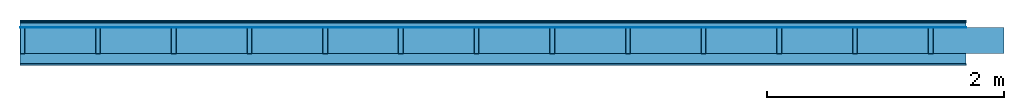
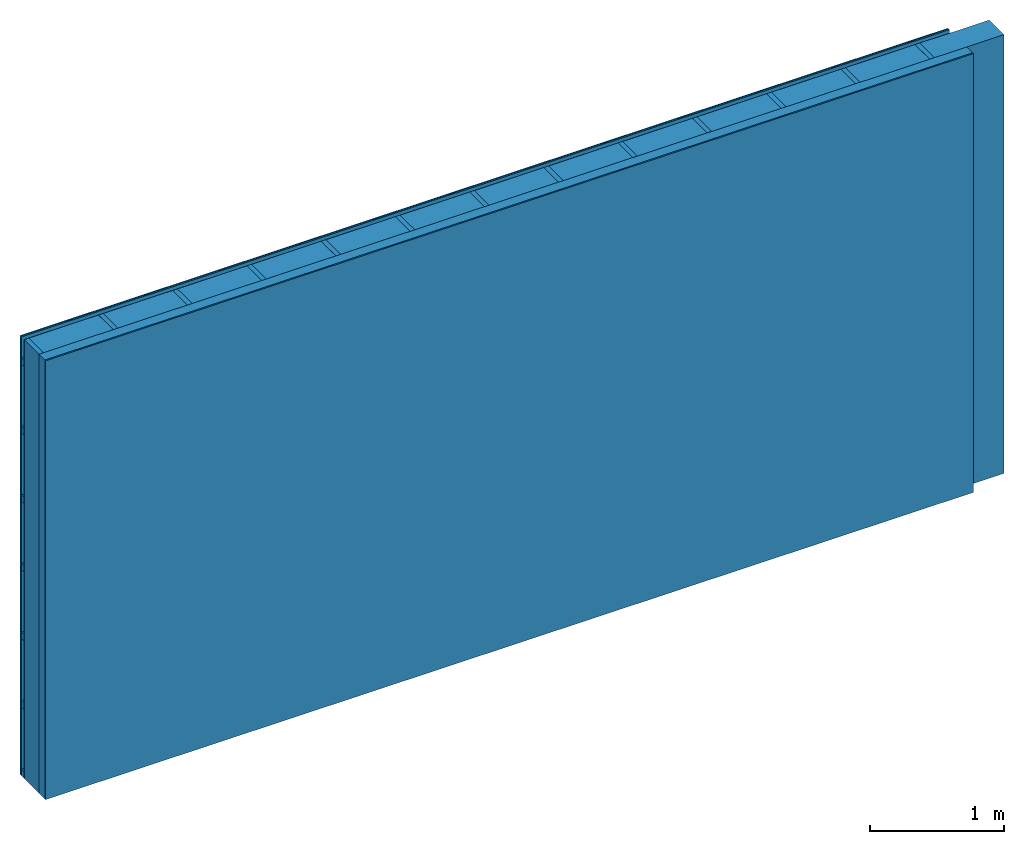
# One storey: 5 plates, 3 members, 1 element without a shape of its own.
"""IFC4 building model written with IfcOpenShell, lengths in metres."""

from ifc_helpers import new_model, si_unit, derived_unit, direction, frame, frame_2d, origin, origin_with_axes, place, context, project, spatial, rectangle, extrude, material, layer, layer_set, type_object, element, aggregate, save


model = new_model("IFC4")

# Units and contexts
plan_context = context("Plan", 3, precision=1e-05, world=origin(), true_north=direction((0.0, 1.0)))
model_context = context("Model", 3, precision=1e-05, world=origin(), true_north=direction((0.0, 1.0)))
ifc_project = project(units=[si_unit("LENGTHUNIT", "METRE"), derived_unit("SOUNDPRESSUREUNIT", [(si_unit("PRESSUREUNIT", "PASCAL", prefix="MICRO"), 0)]), si_unit("ENERGYUNIT", "JOULE", prefix="MEGA"), si_unit("MASSUNIT", "GRAM", prefix="KILO"), derived_unit("THERMALTRANSMITTANCEUNIT", [(si_unit("POWERUNIT", "WATT"), 1), (si_unit("AREAUNIT", "SQUARE_METRE"), -1), (si_unit("THERMODYNAMICTEMPERATUREUNIT", "KELVIN"), -1)]), derived_unit("AREADENSITYUNIT", [(si_unit("MASSUNIT", "GRAM", prefix="KILO"), 1), (si_unit("AREAUNIT", "SQUARE_METRE"), -1)]), derived_unit("USERDEFINED", [(si_unit("ENERGYUNIT", "JOULE", prefix="MEGA"), 1), (si_unit("AREAUNIT", "SQUARE_METRE"), -1)])], contexts=[plan_context, model_context])

# Site, building, storey
site = spatial("IfcSite", under=ifc_project)
building_placement = place(None, origin())
building = spatial("IfcBuilding", under=site, at=building_placement)
storey_placement = place(building_placement, origin())
storey = spatial("IfcBuildingStorey", under=building, at=storey_placement)

# Wall, members, plates
ifc_material_1 = material(Category="04.011")
ifc_layer_1 = layer(ifc_material_1, 0.01, Name="Surface 1")
ifc_material_2 = material(Name="mineral, cement-based building board", Category="03.003")
ifc_layer_2 = layer(ifc_material_2, 0.013, Name="Cover 1st layer")
ifc_layer_3 = layer(None, 0.04, Name="Battens / profiles (ventilation)")
ifc_material_3 = material(Name="Vapor-permeable water barrier", Category="09.006")
ifc_layer_4 = layer(ifc_material_3, 0.0005, Name="outside 1st layer")
ifc_material_4 = material(Name="of the art")
ifc_layer_5 = layer(ifc_material_4, 0.0, Name="Bond")
ifc_layer_6 = layer(None, 0.22, Name="Support")
ifc_layer_7 = layer(ifc_material_4, 0.0, Name="Bond")
ifc_material_5 = material(Name="Solid timber panel")
ifc_layer_8 = layer(ifc_material_5, 0.087, Name="1st layer")
ifc_material_6 = material(Name="Plasterboard type A", Category="03.008")
ifc_layer_9 = layer(ifc_material_6, 0.0125, Name="Covering 1st layer")
ifc_material_7 = material(Name="joints", Category="04.017")
ifc_layer_10 = layer(ifc_material_7, 0.0, Name="Surface")
ifc_layer_set = layer_set([ifc_layer_1, ifc_layer_2, ifc_layer_3, ifc_layer_4, ifc_layer_5, ifc_layer_6, ifc_layer_7, ifc_layer_8, ifc_layer_9, ifc_layer_10])
wall_type = type_object("IfcWallType", Name="D1006", PredefinedType="NOTDEFINED", material=ifc_layer_set)
wall_placement = place(None, frame((0.0, 0.0, 0.0), z_axis=(0.0, -1.0, 0.0), x_axis=(1.0, 0.0, 0.0)))
wall = element("IfcWall", 1, at=wall_placement, inside=storey, type_object=wall_type, material=ifc_layer_set, Name="Wall #1")
ifc_material_8 = material()
member_1_placement = place(wall_placement, origin())
member_1 = element("IfcMember", 2, at=member_1_placement, material=ifc_material_8, Name="Battens / profiles (ventilation)", context=plan_context, shape_type="SweptSolid", body=[
    extrude(rectangle(XDim=0.06, YDim=0.04, at=frame_2d((0.03, 0.02), x_axis=(1.0, 0.0))), frame((0.0, 0.0, 0.023), z_axis=(1.0, 0.0, 0.0), x_axis=(0.0, 1.0, 0.0)), (0.0, 0.0, 1.0), 8.0),
    extrude(rectangle(XDim=0.06, YDim=0.04, at=frame_2d((0.03, 0.02), x_axis=(1.0, 0.0))), frame((0.0, 0.625, 0.023), z_axis=(1.0, 0.0, 0.0), x_axis=(0.0, 1.0, 0.0)), (0.0, 0.0, 1.0), 8.0),
    extrude(rectangle(XDim=0.06, YDim=0.04, at=frame_2d((0.03, 0.02), x_axis=(1.0, 0.0))), frame((0.0, 1.25, 0.023), z_axis=(1.0, 0.0, 0.0), x_axis=(0.0, 1.0, 0.0)), (0.0, 0.0, 1.0), 8.0),
    extrude(rectangle(XDim=0.06, YDim=0.04, at=frame_2d((0.03, 0.02), x_axis=(1.0, 0.0))), frame((0.0, 1.875, 0.023), z_axis=(1.0, 0.0, 0.0), x_axis=(0.0, 1.0, 0.0)), (0.0, 0.0, 1.0), 8.0),
    extrude(rectangle(XDim=0.06, YDim=0.04, at=frame_2d((0.03, 0.02), x_axis=(1.0, 0.0))), frame((0.0, 2.5, 0.023), z_axis=(1.0, 0.0, 0.0), x_axis=(0.0, 1.0, 0.0)), (0.0, 0.0, 1.0), 8.0),
    extrude(rectangle(XDim=0.06, YDim=0.04, at=frame_2d((0.03, 0.02), x_axis=(1.0, 0.0))), frame((0.0, 3.125, 0.023), z_axis=(1.0, 0.0, 0.0), x_axis=(0.0, 1.0, 0.0)), (0.0, 0.0, 1.0), 8.0),
    extrude(rectangle(XDim=0.06, YDim=0.04, at=frame_2d((0.03, 0.02), x_axis=(1.0, 0.0))), frame((0.0, 3.75, 0.023), z_axis=(1.0, 0.0, 0.0), x_axis=(0.0, 1.0, 0.0)), (0.0, 0.0, 1.0), 8.0),
])
ifc_material_9 = material()
member_2_placement = place(wall_placement, origin())
member_2 = element("IfcMember", 3, at=member_2_placement, material=ifc_material_9, Name="Support", context=plan_context, shape_type="SweptSolid", body=[
    extrude(rectangle(XDim=0.04, YDim=0.22, at=frame_2d((0.02, 0.11), x_axis=(1.0, 0.0))), frame((0.0, 4.0, 0.0635), z_axis=(0.0, -1.0, 0.0), x_axis=(1.0, 0.0, 0.0)), (0.0, 0.0, 1.0), 4.0),
    extrude(rectangle(XDim=0.04, YDim=0.22, at=frame_2d((0.02, 0.11), x_axis=(1.0, 0.0))), frame((0.64, 4.0, 0.0635), z_axis=(0.0, -1.0, 0.0), x_axis=(1.0, 0.0, 0.0)), (0.0, 0.0, 1.0), 4.0),
    extrude(rectangle(XDim=0.04, YDim=0.22, at=frame_2d((0.02, 0.11), x_axis=(1.0, 0.0))), frame((1.28, 4.0, 0.0635), z_axis=(0.0, -1.0, 0.0), x_axis=(1.0, 0.0, 0.0)), (0.0, 0.0, 1.0), 4.0),
    extrude(rectangle(XDim=0.04, YDim=0.22, at=frame_2d((0.02, 0.11), x_axis=(1.0, 0.0))), frame((1.92, 4.0, 0.0635), z_axis=(0.0, -1.0, 0.0), x_axis=(1.0, 0.0, 0.0)), (0.0, 0.0, 1.0), 4.0),
    extrude(rectangle(XDim=0.04, YDim=0.22, at=frame_2d((0.02, 0.11), x_axis=(1.0, 0.0))), frame((2.56, 4.0, 0.0635), z_axis=(0.0, -1.0, 0.0), x_axis=(1.0, 0.0, 0.0)), (0.0, 0.0, 1.0), 4.0),
    extrude(rectangle(XDim=0.04, YDim=0.22, at=frame_2d((0.02, 0.11), x_axis=(1.0, 0.0))), frame((3.2, 4.0, 0.0635), z_axis=(0.0, -1.0, 0.0), x_axis=(1.0, 0.0, 0.0)), (0.0, 0.0, 1.0), 4.0),
    extrude(rectangle(XDim=0.04, YDim=0.22, at=frame_2d((0.02, 0.11), x_axis=(1.0, 0.0))), frame((3.84, 4.0, 0.0635), z_axis=(0.0, -1.0, 0.0), x_axis=(1.0, 0.0, 0.0)), (0.0, 0.0, 1.0), 4.0),
    extrude(rectangle(XDim=0.04, YDim=0.22, at=frame_2d((0.02, 0.11), x_axis=(1.0, 0.0))), frame((4.48, 4.0, 0.0635), z_axis=(0.0, -1.0, 0.0), x_axis=(1.0, 0.0, 0.0)), (0.0, 0.0, 1.0), 4.0),
    extrude(rectangle(XDim=0.04, YDim=0.22, at=frame_2d((0.02, 0.11), x_axis=(1.0, 0.0))), frame((5.12, 4.0, 0.0635), z_axis=(0.0, -1.0, 0.0), x_axis=(1.0, 0.0, 0.0)), (0.0, 0.0, 1.0), 4.0),
    extrude(rectangle(XDim=0.04, YDim=0.22, at=frame_2d((0.02, 0.11), x_axis=(1.0, 0.0))), frame((5.76, 4.0, 0.0635), z_axis=(0.0, -1.0, 0.0), x_axis=(1.0, 0.0, 0.0)), (0.0, 0.0, 1.0), 4.0),
    extrude(rectangle(XDim=0.04, YDim=0.22, at=frame_2d((0.02, 0.11), x_axis=(1.0, 0.0))), frame((6.4, 4.0, 0.0635), z_axis=(0.0, -1.0, 0.0), x_axis=(1.0, 0.0, 0.0)), (0.0, 0.0, 1.0), 4.0),
    extrude(rectangle(XDim=0.04, YDim=0.22, at=frame_2d((0.02, 0.11), x_axis=(1.0, 0.0))), frame((7.04, 4.0, 0.0635), z_axis=(0.0, -1.0, 0.0), x_axis=(1.0, 0.0, 0.0)), (0.0, 0.0, 1.0), 4.0),
    extrude(rectangle(XDim=0.04, YDim=0.22, at=frame_2d((0.02, 0.11), x_axis=(1.0, 0.0))), frame((7.68, 4.0, 0.0635), z_axis=(0.0, -1.0, 0.0), x_axis=(1.0, 0.0, 0.0)), (0.0, 0.0, 1.0), 4.0),
])
ifc_material_10 = material(Name="Mineral wool")
member_3_placement = place(wall_placement, origin())
member_3 = element("IfcMember", 4, at=member_3_placement, material=ifc_material_10, Name="Cavity", context=plan_context, shape_type="SweptSolid", body=[
    extrude(rectangle(XDim=0.6, YDim=0.22, at=frame_2d((0.3, 0.11), x_axis=(1.0, 0.0))), frame((0.04, 4.0, 0.0635), z_axis=(0.0, -1.0, 0.0), x_axis=(1.0, 0.0, 0.0)), (0.0, 0.0, 1.0), 4.0),
    extrude(rectangle(XDim=0.6, YDim=0.22, at=frame_2d((0.3, 0.11), x_axis=(1.0, 0.0))), frame((0.68, 4.0, 0.0635), z_axis=(0.0, -1.0, 0.0), x_axis=(1.0, 0.0, 0.0)), (0.0, 0.0, 1.0), 4.0),
    extrude(rectangle(XDim=0.6, YDim=0.22, at=frame_2d((0.3, 0.11), x_axis=(1.0, 0.0))), frame((1.32, 4.0, 0.0635), z_axis=(0.0, -1.0, 0.0), x_axis=(1.0, 0.0, 0.0)), (0.0, 0.0, 1.0), 4.0),
    extrude(rectangle(XDim=0.6, YDim=0.22, at=frame_2d((0.3, 0.11), x_axis=(1.0, 0.0))), frame((1.96, 4.0, 0.0635), z_axis=(0.0, -1.0, 0.0), x_axis=(1.0, 0.0, 0.0)), (0.0, 0.0, 1.0), 4.0),
    extrude(rectangle(XDim=0.6, YDim=0.22, at=frame_2d((0.3, 0.11), x_axis=(1.0, 0.0))), frame((2.6, 4.0, 0.0635), z_axis=(0.0, -1.0, 0.0), x_axis=(1.0, 0.0, 0.0)), (0.0, 0.0, 1.0), 4.0),
    extrude(rectangle(XDim=0.6, YDim=0.22, at=frame_2d((0.3, 0.11), x_axis=(1.0, 0.0))), frame((3.24, 4.0, 0.0635), z_axis=(0.0, -1.0, 0.0), x_axis=(1.0, 0.0, 0.0)), (0.0, 0.0, 1.0), 4.0),
    extrude(rectangle(XDim=0.6, YDim=0.22, at=frame_2d((0.3, 0.11), x_axis=(1.0, 0.0))), frame((3.88, 4.0, 0.0635), z_axis=(0.0, -1.0, 0.0), x_axis=(1.0, 0.0, 0.0)), (0.0, 0.0, 1.0), 4.0),
    extrude(rectangle(XDim=0.6, YDim=0.22, at=frame_2d((0.3, 0.11), x_axis=(1.0, 0.0))), frame((4.52, 4.0, 0.0635), z_axis=(0.0, -1.0, 0.0), x_axis=(1.0, 0.0, 0.0)), (0.0, 0.0, 1.0), 4.0),
    extrude(rectangle(XDim=0.6, YDim=0.22, at=frame_2d((0.3, 0.11), x_axis=(1.0, 0.0))), frame((5.16, 4.0, 0.0635), z_axis=(0.0, -1.0, 0.0), x_axis=(1.0, 0.0, 0.0)), (0.0, 0.0, 1.0), 4.0),
    extrude(rectangle(XDim=0.6, YDim=0.22, at=frame_2d((0.3, 0.11), x_axis=(1.0, 0.0))), frame((5.8, 4.0, 0.0635), z_axis=(0.0, -1.0, 0.0), x_axis=(1.0, 0.0, 0.0)), (0.0, 0.0, 1.0), 4.0),
    extrude(rectangle(XDim=0.6, YDim=0.22, at=frame_2d((0.3, 0.11), x_axis=(1.0, 0.0))), frame((6.44, 4.0, 0.0635), z_axis=(0.0, -1.0, 0.0), x_axis=(1.0, 0.0, 0.0)), (0.0, 0.0, 1.0), 4.0),
    extrude(rectangle(XDim=0.6, YDim=0.22, at=frame_2d((0.3, 0.11), x_axis=(1.0, 0.0))), frame((7.08, 4.0, 0.0635), z_axis=(0.0, -1.0, 0.0), x_axis=(1.0, 0.0, 0.0)), (0.0, 0.0, 1.0), 4.0),
    extrude(rectangle(XDim=0.6, YDim=0.22, at=frame_2d((0.3, 0.11), x_axis=(1.0, 0.0))), frame((7.72, 4.0, 0.0635), z_axis=(0.0, -1.0, 0.0), x_axis=(1.0, 0.0, 0.0)), (0.0, 0.0, 1.0), 4.0),
])
plate_1_placement = place(wall_placement, origin())
plate_1 = element("IfcPlate", 5, at=plate_1_placement, material=ifc_material_1, Name="Surface 1", context=plan_context, shape_type="SweptSolid", body=[
    extrude(rectangle(XDim=8.0, YDim=4.0, at=frame_2d((4.0, 2.0), x_axis=(1.0, 0.0))), origin_with_axes(), (0.0, 0.0, 1.0), 0.01),
])
plate_2_placement = place(wall_placement, origin())
plate_2 = element("IfcPlate", 6, at=plate_2_placement, material=ifc_material_2, Name="Cover 1st layer", context=plan_context, shape_type="SweptSolid", body=[
    extrude(rectangle(XDim=8.0, YDim=4.0, at=frame_2d((4.0, 2.0), x_axis=(1.0, 0.0))), frame((0.0, 0.0, 0.01), z_axis=(0.0, 0.0, 1.0), x_axis=(1.0, 0.0, 0.0)), (0.0, 0.0, 1.0), 0.013),
])
plate_3_placement = place(wall_placement, origin())
plate_3 = element("IfcPlate", 7, at=plate_3_placement, material=ifc_material_3, Name="outside 1st layer", context=plan_context, shape_type="SweptSolid", body=[
    extrude(rectangle(XDim=8.0, YDim=4.0, at=frame_2d((4.0, 2.0), x_axis=(1.0, 0.0))), frame((0.0, 0.0, 0.063), z_axis=(0.0, 0.0, 1.0), x_axis=(1.0, 0.0, 0.0)), (0.0, 0.0, 1.0), 0.0005),
])
plate_4_placement = place(wall_placement, origin())
plate_4 = element("IfcPlate", 8, at=plate_4_placement, material=ifc_material_5, Name="1st layer", context=plan_context, shape_type="SweptSolid", body=[
    extrude(rectangle(XDim=8.0, YDim=4.0, at=frame_2d((4.0, 2.0), x_axis=(1.0, 0.0))), frame((0.0, 0.0, 0.2835), z_axis=(0.0, 0.0, 1.0), x_axis=(1.0, 0.0, 0.0)), (0.0, 0.0, 1.0), 0.087),
])
plate_5_placement = place(wall_placement, origin())
plate_5 = element("IfcPlate", 9, at=plate_5_placement, material=ifc_material_6, Name="Covering 1st layer", context=plan_context, shape_type="SweptSolid", body=[
    extrude(rectangle(XDim=8.0, YDim=4.0, at=frame_2d((4.0, 2.0), x_axis=(1.0, 0.0))), frame((0.0, 0.0, 0.3705), z_axis=(0.0, 0.0, 1.0), x_axis=(1.0, 0.0, 0.0)), (0.0, 0.0, 1.0), 0.0125),
])
aggregate(wall, [plate_1, plate_2, member_1, plate_3, member_2, member_3, plate_4, plate_5])

save(model, "model.ifc")
